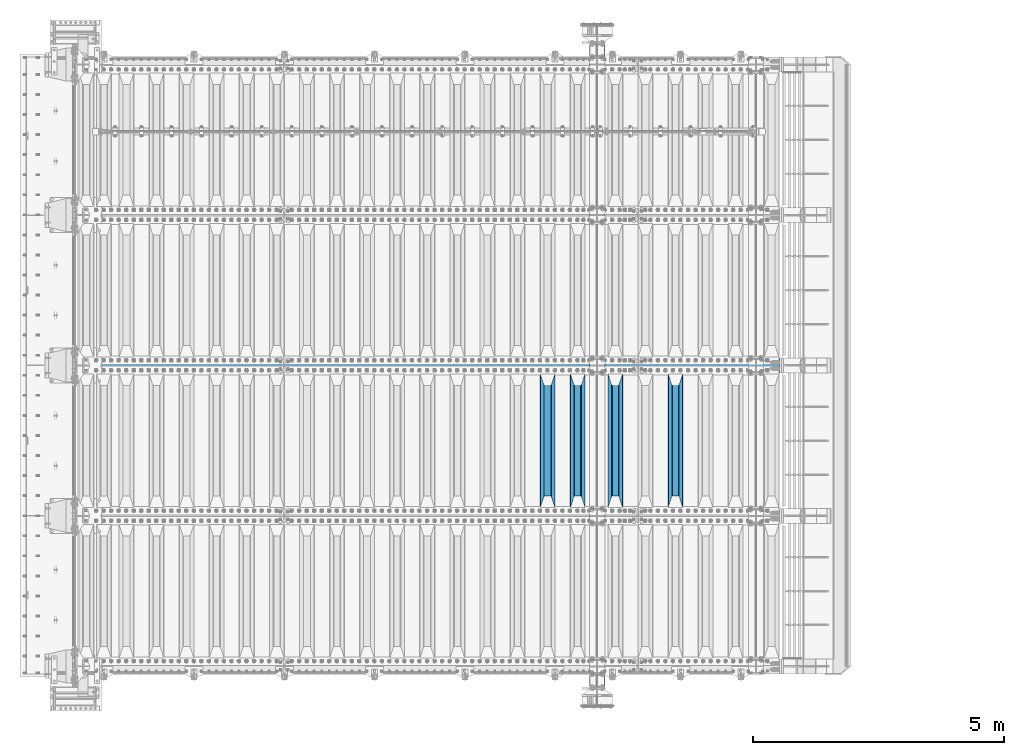
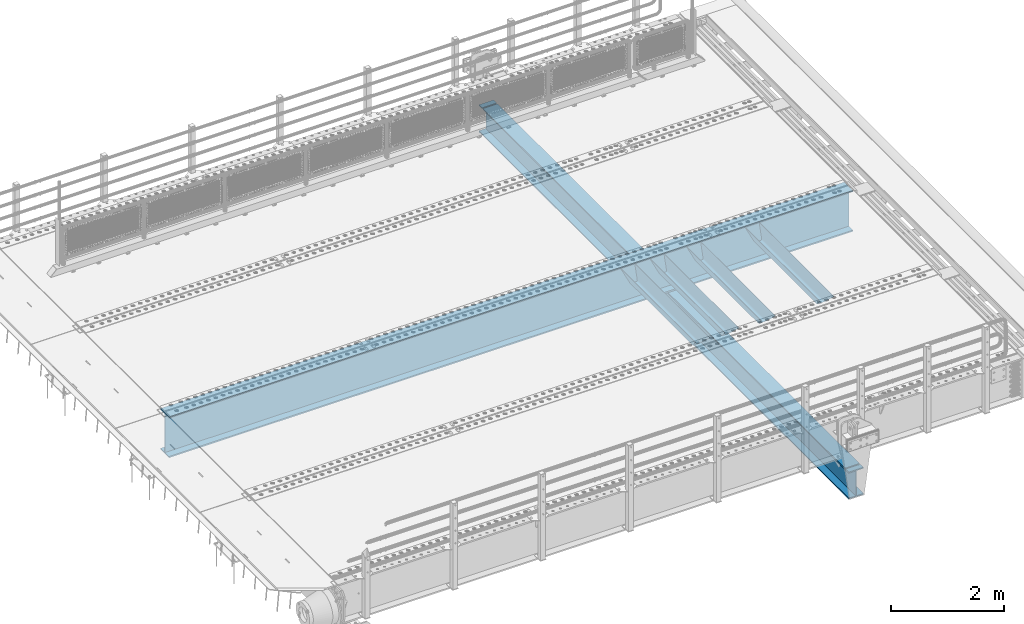
# One storey, part 110 of 240: 6 beams.
"""IFC2X3 building model written with IfcOpenShell, lengths in millimetres."""

import ifcopenshell
import ifcopenshell.guid

model = None  # the IFC model being written
_history = None  # IfcOwnerHistory: only IFC2X3 demands one
_inside = {}  # id of a spatial element -> (the spatial element, [elements in it])
_under = {}  # id of a project, library or spatial element -> (it, [spatial elements below it])
_declared = {}  # id of a project -> (the project, [libraries it declares])
_typed = {}  # id of a type object -> (the type object, [elements of that type])
_made_of = {}  # id of a material, layer set ... -> (it, [elements and type objects made of it])


def new_model(schema):
    """Start an empty IFC model of exactly this schema.

    Asked for "IFC4X3", IfcOpenShell would pick the latest addendum, in which some entities
    have other attributes; the version numbers below select the first issue.
    IFC2X3 requires an IfcOwnerHistory on every rooted entity: one is made here for all.
    """
    global model, _history
    if schema == "IFC4X3":
        model = ifcopenshell.file(schema_version=(4, 3, 0, 0))
    else:
        model = ifcopenshell.file(schema=schema)
    _inside.clear()
    _under.clear()
    _declared.clear()
    _typed.clear()
    _made_of.clear()
    _history = None
    if model.schema == "IFC2X3":
        org = make("IfcOrganization", Name="unknown")
        user = make(
            "IfcPersonAndOrganization",
            ThePerson=make("IfcPerson", FamilyName="unknown"),
            TheOrganization=org,
        )
        app = make(
            "IfcApplication",
            ApplicationDeveloper=org,
            Version="unknown",
            ApplicationFullName="unknown",
            ApplicationIdentifier="unknown",
        )
        _history = make(
            "IfcOwnerHistory",
            OwningUser=user,
            OwningApplication=app,
            ChangeAction="ADDED",
            CreationDate=0,
        )
    return model


def make(cls, **values):
    """One entity of the class cls with the attributes given. An attribute that is None is left unset."""
    return model.create_entity(
        cls, **{name: value for name, value in values.items() if value is not None}
    )


def rooted(cls, **values):
    """An entity with a GlobalId (a new one), such as an element, a storey or a relation."""
    return make(cls, GlobalId=ifcopenshell.guid.new(), OwnerHistory=_history, **values)


def si_unit(unit_type, name, prefix=None):
    """IfcSIUnit, for example si_unit("LENGTHUNIT", "METRE", prefix="MILLI")."""
    return make("IfcSIUnit", UnitType=unit_type, Prefix=prefix, Name=name)


def assignment(units):
    """IfcUnitAssignment: the units of a project."""
    return None if units is None else make("IfcUnitAssignment", Units=units)


def point(xyz):
    """IfcCartesianPoint."""
    return None if xyz is None else make("IfcCartesianPoint", Coordinates=xyz)


def direction(xyz):
    """IfcDirection."""
    return None if xyz is None else make("IfcDirection", DirectionRatios=xyz)


def frame(location, z_axis=None, x_axis=None):
    """IfcAxis2Placement3D, a coordinate frame: its origin and axes. An axis left out is left unset."""
    return make(
        "IfcAxis2Placement3D",
        Location=point(location),
        Axis=direction(z_axis),
        RefDirection=direction(x_axis),
    )


def origin_with_axes():
    """The frame at (0, 0, 0) with the z axis (0, 0, 1) and the x axis (1, 0, 0) written out."""
    return frame((0.0, 0.0, 0.0), z_axis=(0.0, 0.0, 1.0), x_axis=(1.0, 0.0, 0.0))


def place(relative_to, where):
    """IfcLocalPlacement: puts the frame where relative to a parent placement (None: the world)."""
    return make(
        "IfcLocalPlacement", PlacementRelTo=relative_to, RelativePlacement=where
    )


def context(
    kind, dimensions, precision=None, world=None, true_north=None, identifier=None
):
    """IfcGeometricRepresentationContext, for example the 3D "Model" context."""
    return make(
        "IfcGeometricRepresentationContext",
        ContextIdentifier=identifier,
        ContextType=kind,
        CoordinateSpaceDimension=dimensions,
        Precision=precision,
        WorldCoordinateSystem=world,
        TrueNorth=true_north,
    )


def subcontext(parent, identifier, kind, view, scale=None):
    """IfcGeometricRepresentationSubContext, for example "Body" below "Model"."""
    return make(
        "IfcGeometricRepresentationSubContext",
        ContextIdentifier=identifier,
        ContextType=kind,
        ParentContext=parent,
        TargetScale=scale,
        TargetView=view,
    )


def project(units=None, contexts=None):
    """IfcProject with its units and contexts."""
    return rooted(
        "IfcProject",
        Name="project",
        RepresentationContexts=contexts,
        UnitsInContext=assignment(units),
    )


def spatial(cls, under=None, at=None, **own):
    """A site, building, storey or space (cls), placed at a placement, below another one or the project."""
    s = rooted(cls, ObjectPlacement=at, **own)
    if under is not None:
        _under.setdefault(under.id(), (under, []))[1].append(s)
    return s


def faces_of(points, faces, orient=None, outer=None):
    """IfcFace entities. A face is a list of loops; a loop is a list of indices into points, from 0.

    orient and outer hold one flag for each loop. By default every Orientation is true, the
    first loop of a face is its IfcFaceOuterBound and the others are IfcFaceBound.
    """
    made = []
    for i, loops in enumerate(faces):
        bounds = []
        for j, loop in enumerate(loops):
            is_outer = j == 0 if outer is None else outer[i][j]
            bounds.append(
                make(
                    "IfcFaceOuterBound" if is_outer else "IfcFaceBound",
                    Bound=make("IfcPolyLoop", Polygon=[points[k] for k in loop]),
                    Orientation=True if orient is None else orient[i][j],
                )
            )
        made.append(make("IfcFace", Bounds=bounds))
    return made


def faceted_brep(points, faces, orient=None, outer=None, voids=None):
    """IfcFacetedBrep: a solid bounded by flat faces; with voids (closed shells), ...WithVoids."""
    shared = [point(p) for p in points]
    hull = make("IfcClosedShell", CfsFaces=faces_of(shared, faces, orient, outer))
    if voids is None:
        return make("IfcFacetedBrep", Outer=hull)
    return make(
        "IfcFacetedBrepWithVoids",
        Outer=hull,
        Voids=[
            make(cls, CfsFaces=faces_of(shared, fs, o, b)) for cls, fs, o, b in voids
        ],
    )


def shape(context_of_items, identifier, shape_type, items):
    """IfcShapeRepresentation: the items that make up one representation, for example the "Body"."""
    return make(
        "IfcShapeRepresentation",
        ContextOfItems=context_of_items,
        RepresentationIdentifier=identifier,
        RepresentationType=shape_type,
        Items=items,
    )


def material(Name=None, Category=None):
    """IfcMaterial."""
    return make("IfcMaterial", Name=Name, Category=Category)


def made_of(thing, what):
    """Note that an element or type object is made of a material, layer set ...; save() writes the relation."""
    if what is not None:
        _made_of.setdefault(what.id(), (what, []))[1].append(thing)
    return thing


def type_object(cls, material=None, **own):
    """A type object (cls), such as IfcWallType, which elements share."""
    return made_of(rooted(cls, **own), material)


def element(
    cls,
    number,
    at=None,
    inside=None,
    cuts=None,
    type_object=None,
    material=None,
    context=None,
    identifier="Body",
    shape_type=None,
    held_by="IfcProductDefinitionShape",
    body=None,
    shapes=None,
    **own,
):
    """One element of the class cls, such as IfcWall. Its Tag is "e" and its number.

    at: its placement. inside: the storey or other place that contains it. cuts: it is an
    opening in that element (IfcRelVoidsElement). A single representation is given by context,
    identifier, shape_type and body (its items); several are given by shapes. held_by: the class
    of the entity that holds the representations. save() writes the other relations.
    """
    e = rooted(cls, Tag="e%d" % number, ObjectPlacement=at, **own)
    if body is not None:
        shapes = [shape(context, identifier, shape_type, body)]
    if shapes is not None:
        e.Representation = make(held_by, Representations=shapes)
    if inside is not None:
        _inside.setdefault(inside.id(), (inside, []))[1].append(e)
    if cuts is not None:
        rooted(
            "IfcRelVoidsElement", RelatingBuildingElement=cuts, RelatedOpeningElement=e
        )
    if type_object is not None:
        _typed.setdefault(type_object.id(), (type_object, []))[1].append(e)
    return made_of(e, material)


def aggregate(whole, parts):
    """IfcRelAggregates: a whole, such as a stair, and the parts it consists of."""
    return rooted("IfcRelAggregates", RelatingObject=whole, RelatedObjects=parts)


def save(model, path):
    """Write the relations noted so far, then the file.

    IfcRelAggregates (storeys below a building ...), IfcRelContainedInSpatialStructure (elements
    in a storey), IfcRelDefinesByType, IfcRelAssociatesMaterial and IfcRelDeclares: one each for
    every whole, place, type object, material and project.
    """
    for whole, parts in _under.values():
        aggregate(whole, parts)
    for where, things in _inside.values():
        rooted(
            "IfcRelContainedInSpatialStructure",
            RelatedElements=things,
            RelatingStructure=where,
        )
    for kind, things in _typed.values():
        rooted("IfcRelDefinesByType", RelatedObjects=things, RelatingType=kind)
    for what, things in _made_of.values():
        rooted("IfcRelAssociatesMaterial", RelatedObjects=things, RelatingMaterial=what)
    for by, libraries in _declared.values():
        rooted("IfcRelDeclares", RelatingContext=by, RelatedDefinitions=libraries)
    model.write(path)


model = new_model("IFC2X3")

# Units and contexts
model_context = context("Model", 3, precision=1e-05, world=origin_with_axes())
body_context = subcontext(model_context, "Body", "Model", "MODEL_VIEW")
ifc_project = project(units=[si_unit("LENGTHUNIT", "METRE", prefix="MILLI"), si_unit("AREAUNIT", "SQUARE_METRE"), si_unit("VOLUMEUNIT", "CUBIC_METRE"), si_unit("MASSUNIT", "GRAM", prefix="KILO"), si_unit("TIMEUNIT", "SECOND"), si_unit("PLANEANGLEUNIT", "RADIAN"), si_unit("SOLIDANGLEUNIT", "STERADIAN"), si_unit("THERMODYNAMICTEMPERATUREUNIT", "DEGREE_CELSIUS"), si_unit("LUMINOUSINTENSITYUNIT", "LUMEN")], contexts=[model_context])

# Site, building, storey
site_placement = place(None, origin_with_axes())
site = spatial("IfcSite", under=ifc_project, at=site_placement, CompositionType="ELEMENT")
building_placement = place(site_placement, origin_with_axes())
building = spatial("IfcBuilding", under=site, at=building_placement, Name="Standard", CompositionType="ELEMENT")
storey_placement = place(building_placement, origin_with_axes())
storey = spatial("IfcBuildingStorey", under=building, at=storey_placement, Name="Undefined", CompositionType="ELEMENT", Elevation=0.0)

# Beams
ifc_material = material(Name="STEEL/S355N")
beam_type_1 = type_object("IfcBeamType", PredefinedType="NOTDEFINED")
beam_1_placement = place(storey_placement, frame((54400.0, 27175.0, -115.0), z_axis=(0.0, 0.0, 1.0), x_axis=(0.0, 1.0, 0.0)))
element("IfcBeam", 1, at=beam_1_placement, inside=storey, type_object=beam_type_1, material=ifc_material, context=body_context, shape_type="Brep", body=[
    faceted_brep([(0.0, 150.0, 115.0), (0.0, 143.690000000002, 115.0), (2650.00000000297, 143.690000000002, 115.0), (2650.00000000297, 150.0, 115.0), (2650.00000000297, 142.059565218406, 110.000000003094), (2650.00000000297, 148.369565218403, 110.000000003094), (2441.90079219209, -80.1103600731149, -98.0992078077845), (2437.7588105432, -77.5672621345584, -102.241189456673), (2434.06523489747, -74.4080125315522, -105.934765102404), (2430.9108609509, -70.7102721255724, -109.089139048974), (2428.37322971128, -66.5649389910031, -111.626770288588), (2426.51472138055, -62.0739139532889, -113.485278619323), (2425.38102192092, -57.3475956567636, -114.618978078955), (2424.99999999987, -52.5021667386536, -115.0), (2424.99999999987, 52.5021667386536, -115.0), (2425.38102192092, 57.3475956567636, -114.618978078955), (2426.51472138055, 62.0739139532889, -113.485278619323), (2428.37322971128, 66.5649389910031, -111.626770288588), (2430.9108609509, 70.7102721255724, -109.089139048974), (2434.06523489747, 74.4080125315522, -105.934765102404), (2437.7588105432, 77.5672621345584, -102.241189456673), (2441.90079219209, 80.1103600731149, -98.0992078077846), (2446.38936140512, 81.9747917625791, -93.6106385947584), (2448.2494850041, 76.2713538057287, -91.7505149957729), (2444.62967112263, 74.76777986261, -95.3703288772456), (2441.28936334127, 72.7168944282894, -98.710636658607), (2438.31067330439, 70.1691124903809, -101.689326695487), (2435.76682334748, 67.1870637758839, -104.233176652398), (2433.72034654134, 63.8440531834931, -106.279653458539), (2432.22154950042, 60.2222587982324, -107.778450499454), (2431.30727574265, 56.4107117849126, -108.692724257221), (2430.99999999987, 52.5031078186876, -109.0), (2430.99999999987, -52.5031078186876, -109.0), (2431.30727574265, -56.4107117849126, -108.692724257221), (2432.22154950042, -60.2222587982324, -107.778450499454), (2433.72034654134, -63.8440531834931, -106.279653458539), (2435.76682334748, -67.1870637758839, -104.233176652398), (2438.31067330439, -70.1691124903809, -101.689326695487), (2441.28936334127, -72.7168944282894, -98.7106366586071), (2444.62967112263, -74.76777986261, -95.3703288772457), (2448.2494850041, -76.2713538057287, -91.7505149957729), (2650.00000000297, -142.059565218406, 110.000000003094), (2650.00000000297, -148.369565218403, 110.000000003094), (2446.38936140512, -81.9747917625791, -93.6106385947584), (2650.00000000297, -143.690000000002, 115.0), (2650.00000000297, -150.0, 115.0), (0.0, -143.690000000002, 115.0), (0.0, -150.0, 115.0), (0.0, -148.369565218258, 110.000000002667), (203.610638597427, -81.9747917625791, -93.6106385947584), (208.09920781045, -80.1103600731149, -98.0992078077845), (212.241189459342, -77.5672621345584, -102.241189456673), (215.93476510507, -74.4080125315522, -105.934765102404), (219.089139051641, -70.7102721255724, -109.089139048974), (221.626770291256, -66.5649389910031, -111.626770288588), (223.485278621989, -62.0739139532889, -113.485278619323), (224.618978081624, -57.3475956567636, -114.618978078955), (225.000000002663, -52.5021667386536, -115.0), (225.000000002663, 52.5021667386536, -115.0), (224.618978081624, 57.3475956567636, -114.618978078955), (223.485278621989, 62.0739139532889, -113.485278619323), (221.626770291256, 66.5649389910031, -111.626770288588), (219.089139051641, 70.7102721255724, -109.089139048974), (215.93476510507, 74.4080125315522, -105.934765102404), (212.241189459342, 77.5672621345584, -102.241189456673), (208.09920781045, 80.1103600731149, -98.0992078077846), (203.610638597427, 81.9747917625791, -93.6106385947584), (0.0, 148.369565218258, 110.000000002667), (0.0, 142.05956521826, 110.000000002667), (201.750514998439, 76.2713538057287, -91.7505149957729), (205.370328879908, 74.76777986261, -95.3703288772456), (208.710636661275, 72.7168944282894, -98.710636658607), (211.689326698153, 70.1691124903809, -101.689326695487), (214.233176655063, 67.1870637758839, -104.233176652398), (216.279653461206, 63.8440531834931, -106.279653458539), (217.778450502123, 60.2222587982324, -107.778450499454), (218.692724259887, 56.4107117849126, -108.692724257221), (219.000000002667, 52.5031078186876, -109.0), (219.000000002667, -52.5031078186876, -109.0), (218.692724259887, -56.4107117849126, -108.692724257221), (217.778450502123, -60.2222587982324, -107.778450499454), (216.279653461206, -63.8440531834931, -106.279653458539), (214.233176655063, -67.1870637758839, -104.233176652398), (211.689326698153, -70.1691124903809, -101.689326695487), (208.710636661275, -72.7168944282894, -98.7106366586071), (205.370328879915, -74.76777986261, -95.3703288772457), (201.750514998439, -76.2713538057287, -91.7505149957729), (0.0, -142.05956521826, 110.000000002667)], [[[0, 1, 2, 3]], [[3, 2, 4, 5]], [[6, 7, 8, 9, 10, 11, 12, 13, 14, 15, 16, 17, 18, 19, 20, 21, 22, 5, 4, 23, 24, 25, 26, 27, 28, 29, 30, 31, 32, 33, 34, 35, 36, 37, 38, 39, 40, 41, 42, 43]], [[44, 45, 42, 41]], [[46, 47, 45, 44]], [[43, 42, 45, 47, 48, 49]], [[6, 43, 49, 50]], [[7, 6, 50, 51]], [[8, 7, 51, 52]], [[9, 8, 52, 53]], [[10, 9, 53, 54]], [[11, 10, 54, 55]], [[12, 11, 55, 56]], [[13, 12, 56, 57]], [[14, 13, 57, 58]], [[15, 14, 58, 59]], [[16, 15, 59, 60]], [[17, 16, 60, 61]], [[18, 17, 61, 62]], [[19, 18, 62, 63]], [[20, 19, 63, 64]], [[21, 20, 64, 65]], [[22, 21, 65, 66]], [[0, 3, 5, 22, 66, 67]], [[1, 0, 67, 68]], [[23, 4, 2, 1, 68, 69]], [[24, 23, 69, 70]], [[25, 24, 70, 71]], [[26, 25, 71, 72]], [[27, 26, 72, 73]], [[28, 27, 73, 74]], [[29, 28, 74, 75]], [[30, 29, 75, 76]], [[31, 30, 76, 77]], [[32, 31, 77, 78]], [[33, 32, 78, 79]], [[34, 33, 79, 80]], [[35, 34, 80, 81]], [[36, 35, 81, 82]], [[37, 36, 82, 83]], [[38, 37, 83, 84]], [[39, 38, 84, 85]], [[40, 39, 85, 86]], [[46, 44, 41, 40, 86, 87]], [[47, 46, 87, 48]], [[86, 85, 84, 83, 82, 81, 80, 79, 78, 77, 76, 75, 74, 73, 72, 71, 70, 69, 68, 67, 66, 65, 64, 63, 62, 61, 60, 59, 58, 57, 56, 55, 54, 53, 52, 51, 50, 49, 48, 87]]]),
])
beam_2_placement = place(storey_placement, frame((53200.0, 27175.0, -115.0), z_axis=(0.0, 0.0, 1.0), x_axis=(0.0, 1.0, 0.0)))
element("IfcBeam", 2, at=beam_2_placement, inside=storey, type_object=beam_type_1, material=ifc_material, context=body_context, shape_type="Brep", body=[
    faceted_brep([(0.0, 150.0, 115.0), (0.0, 143.690000000002, 115.0), (2650.00000000297, 143.690000000002, 115.0), (2650.00000000297, 150.0, 115.0), (2650.00000000297, 142.059565218406, 110.000000003094), (2650.00000000297, 148.369565218403, 110.000000003094), (2441.90079219209, -80.1103600731149, -98.0992078077845), (2437.7588105432, -77.5672621345584, -102.241189456673), (2434.06523489747, -74.4080125315522, -105.934765102404), (2430.9108609509, -70.7102721255724, -109.089139048974), (2428.37322971128, -66.5649389910031, -111.626770288588), (2426.51472138055, -62.0739139532889, -113.485278619323), (2425.38102192092, -57.3475956567636, -114.618978078955), (2424.99999999987, -52.5021667386536, -115.0), (2424.99999999987, 52.5021667386536, -115.0), (2425.38102192092, 57.3475956567636, -114.618978078955), (2426.51472138055, 62.0739139532889, -113.485278619323), (2428.37322971128, 66.5649389910031, -111.626770288588), (2430.9108609509, 70.7102721255724, -109.089139048974), (2434.06523489747, 74.4080125315522, -105.934765102404), (2437.7588105432, 77.5672621345584, -102.241189456673), (2441.90079219209, 80.1103600731149, -98.0992078077846), (2446.38936140512, 81.9747917625791, -93.6106385947584), (2448.2494850041, 76.2713538057287, -91.7505149957729), (2444.62967112263, 74.76777986261, -95.3703288772456), (2441.28936334127, 72.7168944282894, -98.710636658607), (2438.31067330439, 70.1691124903809, -101.689326695487), (2435.76682334748, 67.1870637758839, -104.233176652398), (2433.72034654134, 63.8440531834931, -106.279653458539), (2432.22154950042, 60.2222587982324, -107.778450499454), (2431.30727574265, 56.4107117849126, -108.692724257221), (2430.99999999987, 52.5031078186876, -109.0), (2430.99999999987, -52.5031078186876, -109.0), (2431.30727574265, -56.4107117849126, -108.692724257221), (2432.22154950042, -60.2222587982324, -107.778450499454), (2433.72034654134, -63.8440531834931, -106.279653458539), (2435.76682334748, -67.1870637758839, -104.233176652398), (2438.31067330439, -70.1691124903809, -101.689326695487), (2441.28936334127, -72.7168944282894, -98.7106366586071), (2444.62967112263, -74.76777986261, -95.3703288772457), (2448.2494850041, -76.2713538057287, -91.7505149957729), (2650.00000000297, -142.059565218406, 110.000000003094), (2650.00000000297, -148.369565218403, 110.000000003094), (2446.38936140512, -81.9747917625791, -93.6106385947584), (2650.00000000297, -143.690000000002, 115.0), (2650.00000000297, -150.0, 115.0), (0.0, -143.690000000002, 115.0), (0.0, -150.0, 115.0), (0.0, -148.369565218258, 110.000000002667), (203.610638597427, -81.9747917625791, -93.6106385947584), (208.09920781045, -80.1103600731149, -98.0992078077845), (212.241189459342, -77.5672621345584, -102.241189456673), (215.93476510507, -74.4080125315522, -105.934765102404), (219.089139051641, -70.7102721255724, -109.089139048974), (221.626770291256, -66.5649389910031, -111.626770288588), (223.485278621989, -62.0739139532889, -113.485278619323), (224.618978081624, -57.3475956567636, -114.618978078955), (225.000000002663, -52.5021667386536, -115.0), (225.000000002663, 52.5021667386536, -115.0), (224.618978081624, 57.3475956567636, -114.618978078955), (223.485278621989, 62.0739139532889, -113.485278619323), (221.626770291256, 66.5649389910031, -111.626770288588), (219.089139051641, 70.7102721255724, -109.089139048974), (215.93476510507, 74.4080125315522, -105.934765102404), (212.241189459342, 77.5672621345584, -102.241189456673), (208.09920781045, 80.1103600731149, -98.0992078077846), (203.610638597427, 81.9747917625791, -93.6106385947584), (0.0, 148.369565218258, 110.000000002667), (0.0, 142.05956521826, 110.000000002667), (201.750514998439, 76.2713538057287, -91.7505149957729), (205.370328879908, 74.76777986261, -95.3703288772456), (208.710636661275, 72.7168944282894, -98.710636658607), (211.689326698153, 70.1691124903809, -101.689326695487), (214.233176655063, 67.1870637758839, -104.233176652398), (216.279653461206, 63.8440531834931, -106.279653458539), (217.778450502123, 60.2222587982324, -107.778450499454), (218.692724259887, 56.4107117849126, -108.692724257221), (219.000000002667, 52.5031078186876, -109.0), (219.000000002667, -52.5031078186876, -109.0), (218.692724259887, -56.4107117849126, -108.692724257221), (217.778450502123, -60.2222587982324, -107.778450499454), (216.279653461206, -63.8440531834931, -106.279653458539), (214.233176655063, -67.1870637758839, -104.233176652398), (211.689326698153, -70.1691124903809, -101.689326695487), (208.710636661275, -72.7168944282894, -98.7106366586071), (205.370328879915, -74.76777986261, -95.3703288772457), (201.750514998439, -76.2713538057287, -91.7505149957729), (0.0, -142.05956521826, 110.000000002667)], [[[0, 1, 2, 3]], [[3, 2, 4, 5]], [[6, 7, 8, 9, 10, 11, 12, 13, 14, 15, 16, 17, 18, 19, 20, 21, 22, 5, 4, 23, 24, 25, 26, 27, 28, 29, 30, 31, 32, 33, 34, 35, 36, 37, 38, 39, 40, 41, 42, 43]], [[44, 45, 42, 41]], [[46, 47, 45, 44]], [[43, 42, 45, 47, 48, 49]], [[6, 43, 49, 50]], [[7, 6, 50, 51]], [[8, 7, 51, 52]], [[9, 8, 52, 53]], [[10, 9, 53, 54]], [[11, 10, 54, 55]], [[12, 11, 55, 56]], [[13, 12, 56, 57]], [[14, 13, 57, 58]], [[15, 14, 58, 59]], [[16, 15, 59, 60]], [[17, 16, 60, 61]], [[18, 17, 61, 62]], [[19, 18, 62, 63]], [[20, 19, 63, 64]], [[21, 20, 64, 65]], [[22, 21, 65, 66]], [[0, 3, 5, 22, 66, 67]], [[1, 0, 67, 68]], [[23, 4, 2, 1, 68, 69]], [[24, 23, 69, 70]], [[25, 24, 70, 71]], [[26, 25, 71, 72]], [[27, 26, 72, 73]], [[28, 27, 73, 74]], [[29, 28, 74, 75]], [[30, 29, 75, 76]], [[31, 30, 76, 77]], [[32, 31, 77, 78]], [[33, 32, 78, 79]], [[34, 33, 79, 80]], [[35, 34, 80, 81]], [[36, 35, 81, 82]], [[37, 36, 82, 83]], [[38, 37, 83, 84]], [[39, 38, 84, 85]], [[40, 39, 85, 86]], [[46, 44, 41, 40, 86, 87]], [[47, 46, 87, 48]], [[86, 85, 84, 83, 82, 81, 80, 79, 78, 77, 76, 75, 74, 73, 72, 71, 70, 69, 68, 67, 66, 65, 64, 63, 62, 61, 60, 59, 58, 57, 56, 55, 54, 53, 52, 51, 50, 49, 48, 87]]]),
])
beam_3_placement = place(storey_placement, frame((52450.0, 27175.0, -115.0), z_axis=(0.0, 0.0, 1.0), x_axis=(0.0, 1.0, 0.0)))
element("IfcBeam", 3, at=beam_3_placement, inside=storey, type_object=beam_type_1, material=ifc_material, context=body_context, shape_type="Brep", body=[
    faceted_brep([(0.0, 150.0, 115.0), (0.0, 143.690000000002, 115.0), (2650.00000000297, 143.690000000002, 115.0), (2650.00000000297, 150.0, 115.0), (2650.00000000297, 142.059565218406, 110.000000003094), (2650.00000000297, 148.369565218403, 110.000000003094), (2441.90079219209, -80.1103600731149, -98.0992078077845), (2437.7588105432, -77.5672621345584, -102.241189456673), (2434.06523489747, -74.4080125315522, -105.934765102404), (2430.9108609509, -70.7102721255724, -109.089139048974), (2428.37322971128, -66.5649389910031, -111.626770288588), (2426.51472138055, -62.0739139532889, -113.485278619323), (2425.38102192092, -57.3475956567636, -114.618978078955), (2424.99999999987, -52.5021667386536, -115.0), (2424.99999999987, 52.5021667386536, -115.0), (2425.38102192092, 57.3475956567636, -114.618978078955), (2426.51472138055, 62.0739139532889, -113.485278619323), (2428.37322971128, 66.5649389910031, -111.626770288588), (2430.9108609509, 70.7102721255724, -109.089139048974), (2434.06523489747, 74.4080125315522, -105.934765102404), (2437.7588105432, 77.5672621345584, -102.241189456673), (2441.90079219209, 80.1103600731149, -98.0992078077846), (2446.38936140512, 81.9747917625791, -93.6106385947584), (2448.2494850041, 76.2713538057287, -91.7505149957729), (2444.62967112263, 74.76777986261, -95.3703288772456), (2441.28936334127, 72.7168944282894, -98.710636658607), (2438.31067330439, 70.1691124903809, -101.689326695487), (2435.76682334748, 67.1870637758839, -104.233176652398), (2433.72034654134, 63.8440531834931, -106.279653458539), (2432.22154950042, 60.2222587982324, -107.778450499454), (2431.30727574265, 56.4107117849126, -108.692724257221), (2430.99999999987, 52.5031078186876, -109.0), (2430.99999999987, -52.5031078186876, -109.0), (2431.30727574265, -56.4107117849126, -108.692724257221), (2432.22154950042, -60.2222587982324, -107.778450499454), (2433.72034654134, -63.8440531834931, -106.279653458539), (2435.76682334748, -67.1870637758839, -104.233176652398), (2438.31067330439, -70.1691124903809, -101.689326695487), (2441.28936334127, -72.7168944282894, -98.7106366586071), (2444.62967112263, -74.76777986261, -95.3703288772457), (2448.2494850041, -76.2713538057287, -91.7505149957729), (2650.00000000297, -142.059565218406, 110.000000003094), (2650.00000000297, -148.369565218403, 110.000000003094), (2446.38936140512, -81.9747917625791, -93.6106385947584), (2650.00000000297, -143.690000000002, 115.0), (2650.00000000297, -150.0, 115.0), (0.0, -143.690000000002, 115.0), (0.0, -150.0, 115.0), (0.0, -148.369565218258, 110.000000002667), (203.610638597427, -81.9747917625791, -93.6106385947584), (208.09920781045, -80.1103600731149, -98.0992078077845), (212.241189459342, -77.5672621345584, -102.241189456673), (215.93476510507, -74.4080125315522, -105.934765102404), (219.089139051641, -70.7102721255724, -109.089139048974), (221.626770291256, -66.5649389910031, -111.626770288588), (223.485278621989, -62.0739139532889, -113.485278619323), (224.618978081624, -57.3475956567636, -114.618978078955), (225.000000002663, -52.5021667386536, -115.0), (225.000000002663, 52.5021667386536, -115.0), (224.618978081624, 57.3475956567636, -114.618978078955), (223.485278621989, 62.0739139532889, -113.485278619323), (221.626770291256, 66.5649389910031, -111.626770288588), (219.089139051641, 70.7102721255724, -109.089139048974), (215.93476510507, 74.4080125315522, -105.934765102404), (212.241189459342, 77.5672621345584, -102.241189456673), (208.09920781045, 80.1103600731149, -98.0992078077846), (203.610638597427, 81.9747917625791, -93.6106385947584), (0.0, 148.369565218258, 110.000000002667), (0.0, 142.05956521826, 110.000000002667), (201.750514998439, 76.2713538057287, -91.7505149957729), (205.370328879908, 74.76777986261, -95.3703288772456), (208.710636661275, 72.7168944282894, -98.710636658607), (211.689326698153, 70.1691124903809, -101.689326695487), (214.233176655063, 67.1870637758839, -104.233176652398), (216.279653461206, 63.8440531834931, -106.279653458539), (217.778450502123, 60.2222587982324, -107.778450499454), (218.692724259887, 56.4107117849126, -108.692724257221), (219.000000002667, 52.5031078186876, -109.0), (219.000000002667, -52.5031078186876, -109.0), (218.692724259887, -56.4107117849126, -108.692724257221), (217.778450502123, -60.2222587982324, -107.778450499454), (216.279653461206, -63.8440531834931, -106.279653458539), (214.233176655063, -67.1870637758839, -104.233176652398), (211.689326698153, -70.1691124903809, -101.689326695487), (208.710636661275, -72.7168944282894, -98.7106366586071), (205.370328879915, -74.76777986261, -95.3703288772457), (201.750514998439, -76.2713538057287, -91.7505149957729), (0.0, -142.05956521826, 110.000000002667)], [[[0, 1, 2, 3]], [[3, 2, 4, 5]], [[6, 7, 8, 9, 10, 11, 12, 13, 14, 15, 16, 17, 18, 19, 20, 21, 22, 5, 4, 23, 24, 25, 26, 27, 28, 29, 30, 31, 32, 33, 34, 35, 36, 37, 38, 39, 40, 41, 42, 43]], [[44, 45, 42, 41]], [[46, 47, 45, 44]], [[43, 42, 45, 47, 48, 49]], [[6, 43, 49, 50]], [[7, 6, 50, 51]], [[8, 7, 51, 52]], [[9, 8, 52, 53]], [[10, 9, 53, 54]], [[11, 10, 54, 55]], [[12, 11, 55, 56]], [[13, 12, 56, 57]], [[14, 13, 57, 58]], [[15, 14, 58, 59]], [[16, 15, 59, 60]], [[17, 16, 60, 61]], [[18, 17, 61, 62]], [[19, 18, 62, 63]], [[20, 19, 63, 64]], [[21, 20, 64, 65]], [[22, 21, 65, 66]], [[0, 3, 5, 22, 66, 67]], [[1, 0, 67, 68]], [[23, 4, 2, 1, 68, 69]], [[24, 23, 69, 70]], [[25, 24, 70, 71]], [[26, 25, 71, 72]], [[27, 26, 72, 73]], [[28, 27, 73, 74]], [[29, 28, 74, 75]], [[30, 29, 75, 76]], [[31, 30, 76, 77]], [[32, 31, 77, 78]], [[33, 32, 78, 79]], [[34, 33, 79, 80]], [[35, 34, 80, 81]], [[36, 35, 81, 82]], [[37, 36, 82, 83]], [[38, 37, 83, 84]], [[39, 38, 84, 85]], [[40, 39, 85, 86]], [[46, 44, 41, 40, 86, 87]], [[47, 46, 87, 48]], [[86, 85, 84, 83, 82, 81, 80, 79, 78, 77, 76, 75, 74, 73, 72, 71, 70, 69, 68, 67, 66, 65, 64, 63, 62, 61, 60, 59, 58, 57, 56, 55, 54, 53, 52, 51, 50, 49, 48, 87]]]),
])
beam_4_placement = place(storey_placement, frame((51850.0, 27175.0, -115.0), z_axis=(0.0, 0.0, 1.0), x_axis=(0.0, 1.0, 0.0)))
element("IfcBeam", 4, at=beam_4_placement, inside=storey, type_object=beam_type_1, material=ifc_material, context=body_context, shape_type="Brep", body=[
    faceted_brep([(0.0, 150.0, 115.0), (0.0, 143.690000000002, 115.0), (2650.00000000297, 143.690000000002, 115.0), (2650.00000000297, 150.0, 115.0), (2650.00000000297, 142.059565218406, 110.000000003094), (2650.00000000297, 148.369565218403, 110.000000003094), (2441.90079219209, -80.1103600731149, -98.0992078077845), (2437.7588105432, -77.5672621345584, -102.241189456673), (2434.06523489747, -74.4080125315522, -105.934765102404), (2430.9108609509, -70.7102721255724, -109.089139048974), (2428.37322971128, -66.5649389910031, -111.626770288588), (2426.51472138055, -62.0739139532889, -113.485278619323), (2425.38102192092, -57.3475956567636, -114.618978078955), (2424.99999999987, -52.5021667386536, -115.0), (2424.99999999987, 52.5021667386536, -115.0), (2425.38102192092, 57.3475956567636, -114.618978078955), (2426.51472138055, 62.0739139532889, -113.485278619323), (2428.37322971128, 66.5649389910031, -111.626770288588), (2430.9108609509, 70.7102721255724, -109.089139048974), (2434.06523489747, 74.4080125315522, -105.934765102404), (2437.7588105432, 77.5672621345584, -102.241189456673), (2441.90079219209, 80.1103600731149, -98.0992078077846), (2446.38936140512, 81.9747917625791, -93.6106385947584), (2448.2494850041, 76.2713538057287, -91.7505149957729), (2444.62967112263, 74.76777986261, -95.3703288772456), (2441.28936334127, 72.7168944282894, -98.710636658607), (2438.31067330439, 70.1691124903809, -101.689326695487), (2435.76682334748, 67.1870637758839, -104.233176652398), (2433.72034654134, 63.8440531834931, -106.279653458539), (2432.22154950042, 60.2222587982324, -107.778450499454), (2431.30727574265, 56.4107117849126, -108.692724257221), (2430.99999999987, 52.5031078186876, -109.0), (2430.99999999987, -52.5031078186876, -109.0), (2431.30727574265, -56.4107117849126, -108.692724257221), (2432.22154950042, -60.2222587982324, -107.778450499454), (2433.72034654134, -63.8440531834931, -106.279653458539), (2435.76682334748, -67.1870637758839, -104.233176652398), (2438.31067330439, -70.1691124903809, -101.689326695487), (2441.28936334127, -72.7168944282894, -98.7106366586071), (2444.62967112263, -74.76777986261, -95.3703288772457), (2448.2494850041, -76.2713538057287, -91.7505149957729), (2650.00000000297, -142.059565218406, 110.000000003094), (2650.00000000297, -148.369565218403, 110.000000003094), (2446.38936140512, -81.9747917625791, -93.6106385947584), (2650.00000000297, -143.690000000002, 115.0), (2650.00000000297, -150.0, 115.0), (0.0, -143.690000000002, 115.0), (0.0, -150.0, 115.0), (0.0, -148.369565218258, 110.000000002667), (203.610638597427, -81.9747917625791, -93.6106385947584), (208.09920781045, -80.1103600731149, -98.0992078077845), (212.241189459342, -77.5672621345584, -102.241189456673), (215.93476510507, -74.4080125315522, -105.934765102404), (219.089139051641, -70.7102721255724, -109.089139048974), (221.626770291256, -66.5649389910031, -111.626770288588), (223.485278621989, -62.0739139532889, -113.485278619323), (224.618978081624, -57.3475956567636, -114.618978078955), (225.000000002663, -52.5021667386536, -115.0), (225.000000002663, 52.5021667386536, -115.0), (224.618978081624, 57.3475956567636, -114.618978078955), (223.485278621989, 62.0739139532889, -113.485278619323), (221.626770291256, 66.5649389910031, -111.626770288588), (219.089139051641, 70.7102721255724, -109.089139048974), (215.93476510507, 74.4080125315522, -105.934765102404), (212.241189459342, 77.5672621345584, -102.241189456673), (208.09920781045, 80.1103600731149, -98.0992078077846), (203.610638597427, 81.9747917625791, -93.6106385947584), (0.0, 148.369565218258, 110.000000002667), (0.0, 142.05956521826, 110.000000002667), (201.750514998439, 76.2713538057287, -91.7505149957729), (205.370328879908, 74.76777986261, -95.3703288772456), (208.710636661275, 72.7168944282894, -98.710636658607), (211.689326698153, 70.1691124903809, -101.689326695487), (214.233176655063, 67.1870637758839, -104.233176652398), (216.279653461206, 63.8440531834931, -106.279653458539), (217.778450502123, 60.2222587982324, -107.778450499454), (218.692724259887, 56.4107117849126, -108.692724257221), (219.000000002667, 52.5031078186876, -109.0), (219.000000002667, -52.5031078186876, -109.0), (218.692724259887, -56.4107117849126, -108.692724257221), (217.778450502123, -60.2222587982324, -107.778450499454), (216.279653461206, -63.8440531834931, -106.279653458539), (214.233176655063, -67.1870637758839, -104.233176652398), (211.689326698153, -70.1691124903809, -101.689326695487), (208.710636661275, -72.7168944282894, -98.7106366586071), (205.370328879915, -74.76777986261, -95.3703288772457), (201.750514998439, -76.2713538057287, -91.7505149957729), (0.0, -142.05956521826, 110.000000002667)], [[[0, 1, 2, 3]], [[3, 2, 4, 5]], [[6, 7, 8, 9, 10, 11, 12, 13, 14, 15, 16, 17, 18, 19, 20, 21, 22, 5, 4, 23, 24, 25, 26, 27, 28, 29, 30, 31, 32, 33, 34, 35, 36, 37, 38, 39, 40, 41, 42, 43]], [[44, 45, 42, 41]], [[46, 47, 45, 44]], [[43, 42, 45, 47, 48, 49]], [[6, 43, 49, 50]], [[7, 6, 50, 51]], [[8, 7, 51, 52]], [[9, 8, 52, 53]], [[10, 9, 53, 54]], [[11, 10, 54, 55]], [[12, 11, 55, 56]], [[13, 12, 56, 57]], [[14, 13, 57, 58]], [[15, 14, 58, 59]], [[16, 15, 59, 60]], [[17, 16, 60, 61]], [[18, 17, 61, 62]], [[19, 18, 62, 63]], [[20, 19, 63, 64]], [[21, 20, 64, 65]], [[22, 21, 65, 66]], [[0, 3, 5, 22, 66, 67]], [[1, 0, 67, 68]], [[23, 4, 2, 1, 68, 69]], [[24, 23, 69, 70]], [[25, 24, 70, 71]], [[26, 25, 71, 72]], [[27, 26, 72, 73]], [[28, 27, 73, 74]], [[29, 28, 74, 75]], [[30, 29, 75, 76]], [[31, 30, 76, 77]], [[32, 31, 77, 78]], [[33, 32, 78, 79]], [[34, 33, 79, 80]], [[35, 34, 80, 81]], [[36, 35, 81, 82]], [[37, 36, 82, 83]], [[38, 37, 83, 84]], [[39, 38, 84, 85]], [[40, 39, 85, 86]], [[46, 44, 41, 40, 86, 87]], [[47, 46, 87, 48]], [[86, 85, 84, 83, 82, 81, 80, 79, 78, 77, 76, 75, 74, 73, 72, 71, 70, 69, 68, 67, 66, 65, 64, 63, 62, 61, 60, 59, 58, 57, 56, 55, 54, 53, 52, 51, 50, 49, 48, 87]]]),
])
beam_type_2 = type_object("IfcBeamType", Name="HEA900", PredefinedType="NOTDEFINED")
beam_5_placement = place(storey_placement, frame((42460.0, 30000.0, -445.0), z_axis=(0.0, 0.0, 1.0), x_axis=(1.0, 0.0, 0.0)))
element("IfcBeam", 5, at=beam_5_placement, inside=storey, type_object=beam_type_2, material=ifc_material, ObjectType="HEA900", context=body_context, shape_type="Brep", body=[
    faceted_brep([(0.0, 150.0, -445.0), (0.0, 150.0, -415.0), (14017.0, 150.0, -415.0), (14017.0, 150.0, -445.0), (0.0, 8.0, -415.0), (14017.0, 8.0, -415.0), (0.0, 8.0, 415.0), (14017.0, 8.0, 415.0), (0.0, 150.0, 415.0), (14017.0, 150.0, 415.0), (0.0, 150.0, 445.0), (14017.0, 150.0, 445.0), (0.0, -150.0, 445.0), (14017.0, -150.0, 445.0), (0.0, -150.0, 415.0), (14017.0, -150.0, 415.0), (0.0, -8.0, 415.0), (14017.0, -8.0, 415.0), (0.0, -8.0, -415.0), (14017.0, -8.0, -415.0), (0.0, -150.0, -415.0), (14017.0, -150.0, -415.0), (0.0, -150.0, -445.0), (14017.0, -150.0, -445.0)], [[[0, 1, 2, 3]], [[1, 4, 5, 2]], [[4, 6, 7, 5]], [[6, 8, 9, 7]], [[8, 10, 11, 9]], [[10, 12, 13, 11]], [[12, 14, 15, 13]], [[14, 16, 17, 15]], [[16, 18, 19, 17]], [[18, 20, 21, 19]], [[20, 22, 23, 21]], [[22, 0, 3, 23]], [[5, 7, 9, 11, 13, 15, 17, 19, 21, 23, 3, 2]], [[22, 20, 18, 16, 14, 12, 10, 8, 6, 4, 1, 0]]]),
])
beam_type_3 = type_object("IfcBeamType", Name="HEA600", PredefinedType="NOTDEFINED")
beam_6_placement = place(storey_placement, frame((52840.0, 23435.0000000345, -1185.00001822227), z_axis=(0.0, 0.0, 1.0), x_axis=(0.0, 1.0, 0.0)))
element("IfcBeam", 6, at=beam_6_placement, inside=storey, type_object=beam_type_3, material=ifc_material, ObjectType="HEA600", context=body_context, shape_type="Brep", body=[
    faceted_brep([(12990.0, -150.0, 295.0), (12990.0, -150.0, 270.0), (12990.0, -6.5, 270.0), (12990.0, -6.5, 295.0), (13020.0, -6.5, 270.0), (13020.0, -6.5, 295.0), (13020.0, -150.0, 295.0), (13020.0, -150.0, 270.0), (13130.0, -150.0, 270.0), (13130.0, -150.0, 295.0), (13130.0, -6.5, 270.0), (13130.0, 150.0, 295.0), (13130.0, 150.0, 270.0), (13020.0, 150.0, 270.0), (13020.0, 150.0, 295.0), (140.000000114262, 6.5, 270.0), (140.000000394779, 150.0, 270.0), (12990.0, 150.0, 270.0), (12990.0, 6.5, 270.0), (0.0, -150.0, -295.0), (0.0, 150.0, -295.0), (13130.0, 150.0, -295.0), (13130.0, -150.0, -295.0), (13020.0, -150.0, -270.0), (12990.0, -150.0, -270.0), (139.999999808326, -150.0, -270.0), (109.999999808329, -150.0, -270.0), (0.0, -150.0, -270.0), (13130.0, -150.0, -270.0), (13020.0, -6.5, -270.0), (12990.0, -6.5, -270.0), (140.000000095162, -6.5, -270.0), (110.00000009533, -6.5, -270.0), (0.0, -6.5, -270.0), (13130.0, -6.5, -270.0), (0.0, -150.0, 270.0), (0.0, -6.5, 270.0), (110.000000095326, -6.5, 270.0), (109.999999808326, -150.0, 270.0), (139.999999808326, -150.0, 295.0), (140.000000095162, -6.5, 295.0), (140.000000095162, -6.5, 270.0), (139.999999808326, -150.0, 270.0), (110.000000095326, -6.49999994000245, 295.0), (109.999999808326, -150.0, 295.0), (0.0, -150.0, 295.0), (0.0, 6.5, 270.0), (0.0, 150.0, 270.0), (110.000000394783, 150.0, 270.0), (110.000000394783, 6.5, 270.0), (0.0, 150.0, 295.0), (0.0, 6.5, -270.0), (0.0, 150.0, -270.0), (110.000000394783, 150.0, 295.0), (110.000000394783, 6.5, 295.0), (140.000000114262, 6.5, 295.0), (140.000000394779, 150.0, 295.0), (12990.0, 150.0, 295.0), (12990.0, 6.5, 295.0), (13020.0, 6.5, 295.0), (13020.0, 6.5, 270.0), (13130.0, 6.5, 270.0), (13020.0, 6.5, -270.0), (12990.0, 6.5, -270.0), (140.000000114262, 6.5, -270.0), (110.000000394783, 6.5, -270.0), (13130.0, 6.5, -270.0), (13020.0, 150.0, -270.0), (12990.0, 150.0, -270.0), (140.000000394786, 150.0, -270.0), (110.000000394783, 150.0, -270.0), (13130.0, 150.0, -270.0)], [[[0, 1, 2, 3]], [[3, 2, 4, 5]], [[6, 5, 4, 7]], [[8, 9, 6, 7]], [[10, 8, 7, 4]], [[11, 12, 13, 14]], [[15, 16, 17, 18]], [[19, 20, 21, 22]], [[23, 24, 25, 26, 27, 19, 22, 28]], [[29, 30, 31, 32, 33, 27, 26, 25, 24, 23, 28, 34]], [[35, 36, 37, 38]], [[39, 40, 41, 42]], [[43, 37, 41, 40]], [[44, 38, 37, 43]], [[45, 35, 38, 44]], [[46, 47, 48, 49]], [[19, 27, 33, 36, 35, 45, 50, 47, 46, 51, 52, 20]], [[47, 50, 53, 48]], [[54, 49, 48, 53]], [[55, 15, 49, 54]], [[56, 16, 15, 55]], [[16, 56, 57, 17]], [[58, 18, 17, 57]], [[59, 60, 18, 58]], [[14, 13, 60, 59]], [[12, 61, 60, 13]], [[62, 63, 64, 65, 51, 46, 49, 15, 18, 60, 61, 66]], [[67, 68, 69, 70, 52, 51, 65, 64, 63, 62, 66, 71]], [[20, 52, 70, 69, 68, 67, 71, 21]], [[66, 61, 12, 11, 9, 8, 10, 34, 28, 22, 21, 71]], [[4, 2, 41, 37, 36, 33, 32, 31, 30, 29, 34, 10]], [[42, 41, 2, 1]], [[39, 42, 1, 0]], [[9, 11, 14, 59, 58, 57, 56, 55, 54, 53, 50, 45, 44, 43, 40, 39, 0, 3, 5, 6]]]),
])

save(model, "model.ifc")
